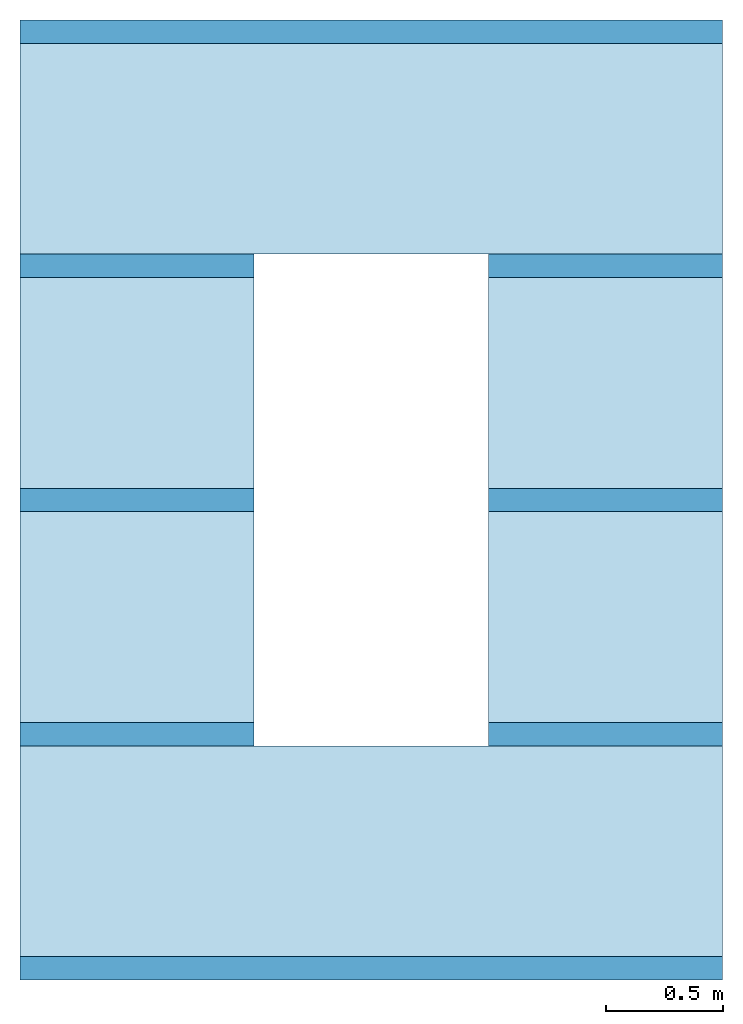
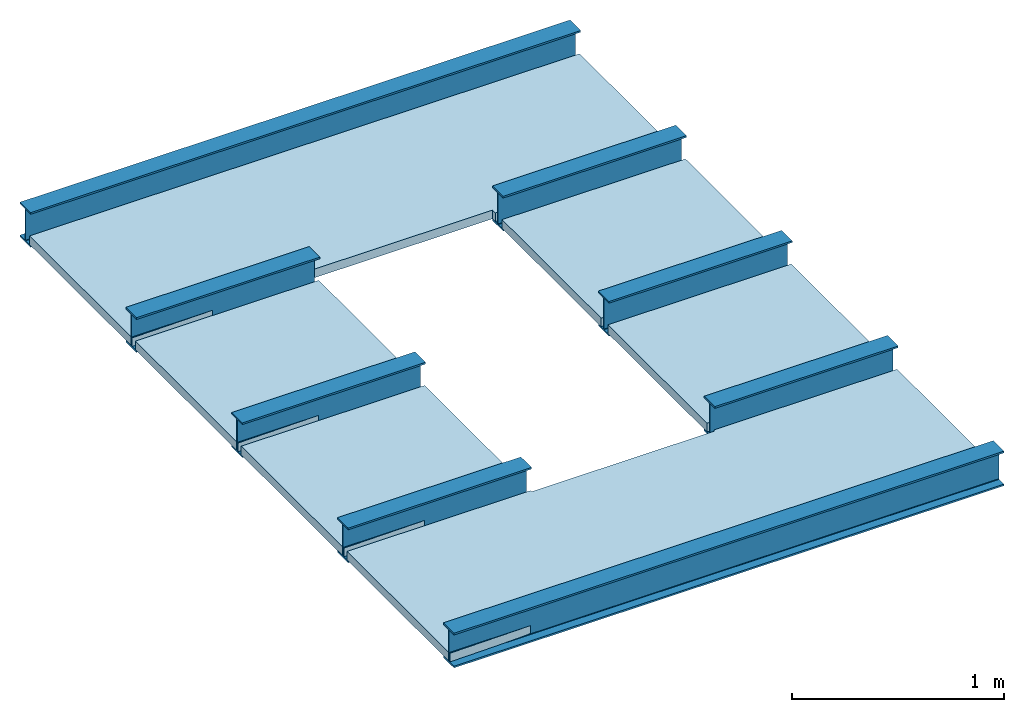
# One storey: 5 beams, 4 slabs, 1 opening, 1 element without a shape of its own.
"""IFC4 building model written with IfcOpenShell, lengths in metres."""

from ifc_helpers import new_model, entity, si_unit, converted_unit, frame, origin_with_axes, origin_2d_with_axis, place, context, subcontext, project, spatial, line, indexed_curve, i_section, outline, extrude, material, layer, layer_set, layer_usage, material_profile, profile_set, profile_usage, type_object, element, aggregate, save


model = new_model("IFC4")

# Units and contexts
model_context = context("Model", 3, precision=1e-05, world=origin_with_axes())
plan_context = context("Plan", 2, precision=1e-05, world=origin_2d_with_axis())
body_context = subcontext(model_context, "Body", "Model", "MODEL_VIEW")
ifc_project = project(units=[converted_unit("PLANEANGLEUNIT", "degree", entity("IfcReal", 0.0174532925199433), si_unit("PLANEANGLEUNIT", "RADIAN"), dimensions=[0, 0, 0, 0, 0, 0, 0]), si_unit("AREAUNIT", "SQUARE_METRE"), si_unit("VOLUMEUNIT", "CUBIC_METRE"), si_unit("LENGTHUNIT", "METRE")], contexts=[model_context, plan_context])

# Site, building, storey
site_placement = place(None, origin_with_axes())
site = spatial("IfcSite", under=ifc_project, at=site_placement)
building_placement = place(site_placement, origin_with_axes())
building = spatial("IfcBuilding", under=site, at=building_placement, Name="Building")
storey_placement = place(building_placement, origin_with_axes())
storey = spatial("IfcBuildingStorey", under=building, at=storey_placement, Name="Storey")

# Assembly, opening, beams, slabs
assembly_placement = place(storey_placement, origin_with_axes())
assembly = element("IfcElementAssembly", 1, at=assembly_placement, inside=storey, Name="Assembly")
opening_placement = place(assembly_placement, frame((1.75, 1.19999980926514, 0.0421054810285568), z_axis=(0.0, 0.0, 1.0), x_axis=(1.0, 0.0, 0.0)))
element("IfcOpeningElement", 2, at=opening_placement, cuts=assembly, Name="Opening", context=body_context, shape_type="SweptSolid", body=[
    extrude(outline(indexed_curve([(-0.25, -0.249999821186066), (0.75, -0.249999821186066), (0.75, 1.85000014305115), (-0.25, 1.85000014305115)], segments=[line(3, 2), line(2, 1), line(1, 4), line(4, 3)], self_intersect=False)), frame((0.0, 0.0, -0.25), z_axis=(0.0, 0.0, -1.0), x_axis=(-1.0, 0.0, 0.0)), (0.0, 0.0, -1.0), 0.5),
])
ifc_material_1 = material(Name="my_material")
ifc_material_profile = material_profile(ifc_material_1, i_section(OverallWidth=0.1, OverallDepth=0.2, WebThickness=0.005, FlangeThickness=0.01, FilletRadius=0.005))
ifc_profile_set = profile_set([ifc_material_profile])
ifc_profile_usage_1 = profile_usage(ifc_profile_set, cardinal=5)
beam_type = type_object("IfcBeamType", Name="B1", PredefinedType="NOTDEFINED", material=ifc_profile_set)
beam_1_placement = place(assembly_placement, frame((0.0, 0.0, 0.0), z_axis=(1.0, -7.54979012640433e-08, 7.54979012640433e-08), x_axis=(7.54979012640433e-08, 1.0, 7.16093850883226e-15)))
beam_1 = element("IfcBeam", 3, at=beam_1_placement, type_object=beam_type, material=ifc_profile_usage_1, Name="Beam", context=body_context, shape_type="SweptSolid", body=[
    extrude(i_section(OverallWidth=0.1, OverallDepth=0.2, WebThickness=0.005, FlangeThickness=0.01, FilletRadius=0.005), origin_with_axes(), (0.0, 0.0, 1.0), 3.00000000000002),
])
ifc_profile_usage_2 = profile_usage(ifc_profile_set, cardinal=5)
beam_2_placement = place(assembly_placement, frame((0.0, 1.0, 0.0), z_axis=(1.0, -7.54979012640433e-08, 7.54979012640433e-08), x_axis=(7.54979012640433e-08, 1.0, 7.16093850883226e-15)))
beam_2 = element("IfcBeam", 4, at=beam_2_placement, type_object=beam_type, material=ifc_profile_usage_2, Name="Beam", context=body_context, shape_type="SweptSolid", body=[
    extrude(i_section(OverallWidth=0.1, OverallDepth=0.2, WebThickness=0.005, FlangeThickness=0.01, FilletRadius=0.005), origin_with_axes(), (0.0, 0.0, 1.0), 3.00000000000002),
])
ifc_profile_usage_3 = profile_usage(ifc_profile_set, cardinal=5)
beam_3_placement = place(assembly_placement, frame((0.0, 2.0, 0.0), z_axis=(1.0, -7.54979012640433e-08, 7.54979012640433e-08), x_axis=(7.54979012640433e-08, 1.0, 7.16093850883226e-15)))
beam_3 = element("IfcBeam", 5, at=beam_3_placement, type_object=beam_type, material=ifc_profile_usage_3, Name="Beam", context=body_context, shape_type="SweptSolid", body=[
    extrude(i_section(OverallWidth=0.1, OverallDepth=0.2, WebThickness=0.005, FlangeThickness=0.01, FilletRadius=0.005), origin_with_axes(), (0.0, 0.0, 1.0), 3.00000000000002),
])
ifc_profile_usage_4 = profile_usage(ifc_profile_set, cardinal=5)
beam_4_placement = place(assembly_placement, frame((0.0, 3.0, 0.0), z_axis=(1.0, -7.54979012640433e-08, 7.54979012640433e-08), x_axis=(7.54979012640433e-08, 1.0, 7.16093850883226e-15)))
beam_4 = element("IfcBeam", 6, at=beam_4_placement, type_object=beam_type, material=ifc_profile_usage_4, Name="Beam", context=body_context, shape_type="SweptSolid", body=[
    extrude(i_section(OverallWidth=0.1, OverallDepth=0.2, WebThickness=0.005, FlangeThickness=0.01, FilletRadius=0.005), origin_with_axes(), (0.0, 0.0, 1.0), 3.00000000000002),
])
ifc_profile_usage_5 = profile_usage(ifc_profile_set, cardinal=5)
beam_5_placement = place(assembly_placement, frame((0.0, 4.0, 0.0), z_axis=(1.0, -7.54979012640433e-08, 7.54979012640433e-08), x_axis=(7.54979012640433e-08, 1.0, 7.16093850883226e-15)))
beam_5 = element("IfcBeam", 7, at=beam_5_placement, type_object=beam_type, material=ifc_profile_usage_5, Name="Beam", context=body_context, shape_type="SweptSolid", body=[
    extrude(i_section(OverallWidth=0.1, OverallDepth=0.2, WebThickness=0.005, FlangeThickness=0.01, FilletRadius=0.005), origin_with_axes(), (0.0, 0.0, 1.0), 3.00000000000002),
])
ifc_material_2 = material()
ifc_layer = layer(ifc_material_2, 0.0500000007450581)
ifc_layer_set = layer_set([ifc_layer])
ifc_layer_usage_1 = layer_usage(ifc_layer_set, "AXIS3", "POSITIVE", 0.0)
slab_type = type_object("IfcSlabType", Name="FLR150", PredefinedType="NOTDEFINED", material=ifc_layer_set)
slab_1_placement = place(assembly_placement, frame((0.0, 0.0, -0.0899997800588608), z_axis=(0.0, 0.0, 1.0), x_axis=(1.0, 0.0, 0.0)))
slab_1 = element("IfcSlab", 8, at=slab_1_placement, type_object=slab_type, material=ifc_layer_usage_1, Name="Slab", context=body_context, shape_type="SweptSolid", body=[
    extrude(outline(indexed_curve([(3.0, 0.959999740123749), (3.0, 0.0399997755885124), (0.0, -0.0100004766136408), (0.0, 0.959999740123749)], segments=[line(4, 1), line(1, 2), line(2, 3), line(3, 4)], self_intersect=False)), None, (0.0, 0.0, 1.0), 0.0500000007450581),
])
ifc_layer_usage_2 = layer_usage(ifc_layer_set, "AXIS3", "POSITIVE", 0.0)
slab_2_placement = place(assembly_placement, frame((0.0, 1.0, -0.0899997800588608), z_axis=(0.0, 0.0, 1.0), x_axis=(1.0, 0.0, 0.0)))
slab_2 = element("IfcSlab", 9, at=slab_2_placement, type_object=slab_type, material=ifc_layer_usage_2, Name="Slab", context=body_context, shape_type="SweptSolid", body=[
    extrude(outline(indexed_curve([(3.0, 0.959999740123749), (3.0, 0.0399997755885124), (0.0, -0.0100004766136408), (0.0, 0.959999740123749)], segments=[line(4, 1), line(1, 2), line(2, 3), line(3, 4)], self_intersect=False)), None, (0.0, 0.0, 1.0), 0.0500000007450581),
])
ifc_layer_usage_3 = layer_usage(ifc_layer_set, "AXIS3", "POSITIVE", 0.0)
slab_3_placement = place(assembly_placement, frame((0.0, 2.0, -0.0899997800588608), z_axis=(0.0, 0.0, 1.0), x_axis=(1.0, 0.0, 0.0)))
slab_3 = element("IfcSlab", 10, at=slab_3_placement, type_object=slab_type, material=ifc_layer_usage_3, Name="Slab", context=body_context, shape_type="SweptSolid", body=[
    extrude(outline(indexed_curve([(3.0, 0.959999740123749), (3.0, 0.0399997755885124), (0.0, -0.0100004766136408), (0.0, 0.959999740123749)], segments=[line(4, 1), line(1, 2), line(2, 3), line(3, 4)], self_intersect=False)), None, (0.0, 0.0, 1.0), 0.0500000007450581),
])
ifc_layer_usage_4 = layer_usage(ifc_layer_set, "AXIS3", "POSITIVE", 0.0)
slab_4_placement = place(assembly_placement, frame((0.0, 3.0, -0.0899997800588608), z_axis=(0.0, 0.0, 1.0), x_axis=(1.0, 0.0, 0.0)))
slab_4 = element("IfcSlab", 11, at=slab_4_placement, type_object=slab_type, material=ifc_layer_usage_4, Name="Slab", context=body_context, shape_type="SweptSolid", body=[
    extrude(outline(indexed_curve([(3.0, 0.959999740123749), (3.0, 0.0399997755885124), (0.0, -0.0100004766136408), (0.0, 0.959999740123749)], segments=[line(4, 1), line(1, 2), line(2, 3), line(3, 4)], self_intersect=False)), None, (0.0, 0.0, 1.0), 0.0500000007450581),
])
aggregate(assembly, [beam_1, beam_2, beam_3, beam_4, beam_5, slab_1, slab_2, slab_3, slab_4])

save(model, "model.ifc")
